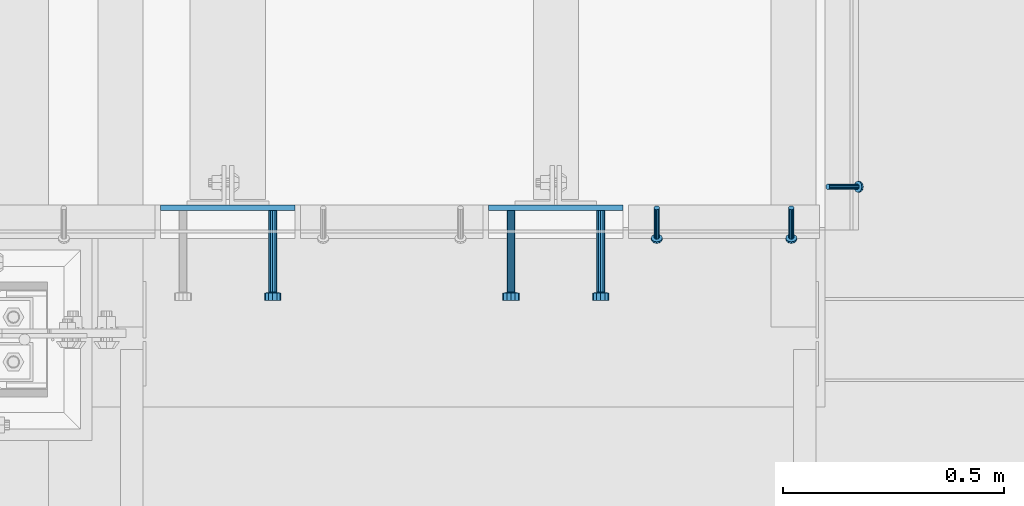
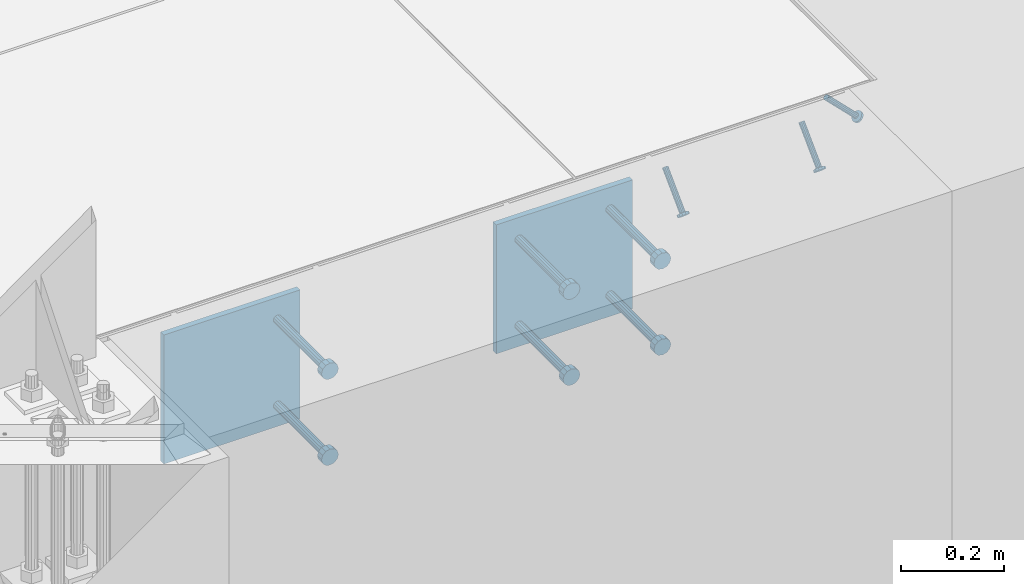
# One storey, part 2041 of 3843: 8 beams, 3 members, 4 elements without a shape of their own.
"""IFC2X3 building model written with IfcOpenShell, lengths in millimetres."""

from ifc_helpers import new_model, si_unit, frame, origin_with_axes, place, context, subcontext, project, spatial, faceted_brep, material, type_object, element, aggregate, save


model = new_model("IFC2X3")

# Units and contexts
model_context = context("Model", 3, precision=1e-05, world=origin_with_axes())
body_context = subcontext(model_context, "Body", "Model", "MODEL_VIEW")
ifc_project = project(units=[si_unit("LENGTHUNIT", "METRE", prefix="MILLI"), si_unit("AREAUNIT", "SQUARE_METRE"), si_unit("VOLUMEUNIT", "CUBIC_METRE"), si_unit("MASSUNIT", "GRAM", prefix="KILO"), si_unit("TIMEUNIT", "SECOND"), si_unit("PLANEANGLEUNIT", "RADIAN"), si_unit("SOLIDANGLEUNIT", "STERADIAN"), si_unit("THERMODYNAMICTEMPERATUREUNIT", "DEGREE_CELSIUS"), si_unit("LUMINOUSINTENSITYUNIT", "LUMEN")], contexts=[model_context])

# Site, building, storey
site_placement = place(None, origin_with_axes())
site = spatial("IfcSite", under=ifc_project, at=site_placement, CompositionType="ELEMENT")
building_placement = place(site_placement, origin_with_axes())
building = spatial("IfcBuilding", under=site, at=building_placement, Name="Undefined", CompositionType="ELEMENT")
storey_placement = place(building_placement, origin_with_axes())
storey = spatial("IfcBuildingStorey", under=building, at=storey_placement, Name="Undefined", CompositionType="ELEMENT", Elevation=0.0)

# Assembly, members
assembly_1_placement = place(storey_placement, origin_with_axes())
assembly_1 = element("IfcElementAssembly", 1, at=assembly_1_placement, inside=storey, Name="ANGLE", AssemblyPlace="NOTDEFINED", PredefinedType="RIGID_FRAME")
ifc_material_1 = material(Name="STEEL/A108")
member_type = type_object("IfcMemberType", PredefinedType="NOTDEFINED")
member_1_placement = place(assembly_1_placement, frame((50504.724998711, 15297.1500129542, 30397.4500030518), z_axis=(1.0, 0.0, 0.0), x_axis=(0.0, -0.707106781186548, -0.707106781186548)))
member_1 = element("IfcMember", 2, at=member_1_placement, type_object=member_type, material=ifc_material_1, Name="HEADED STUD ANCHOR", context=body_context, shape_type="Brep", body=[
    faceted_brep([(7.27595761418343e-12, -3.18000006675175, 5.5), (0.0, -5.49999999998363, 3.1800000667572), (94.4879985803855, -5.50000000011278, 3.1800000667572), (94.4879985803782, -3.18000006687362, 5.5), (0.0, -6.3499999046162, 0.0), (94.4879985803855, -6.34999990474535, 0.0), (0.0, -5.49999999998363, -3.1800000667572), (94.4879985803855, -5.50000000011278, -3.1800000667572), (7.27595761418343e-12, -3.18000006675175, -5.5), (94.4879985803782, -3.18000006687362, -5.5), (7.27595761418343e-12, -1.81898940354586e-12, -6.34999990463257), (94.4879985803782, -1.20053300634027e-10, -6.34999990463257), (0.0, 3.18000006675175, -5.5), (94.4879985803709, 3.18000006663351, -5.5), (7.27595761418343e-12, 5.49999999998363, -3.1800000667572), (94.4879985803709, 5.49999999987267, -3.1800000667572), (7.27595761418343e-12, 6.3499999046162, 0.0), (94.4879985803673, 6.34999990450706, 0.0), (7.27595761418343e-12, 5.49999999998363, 3.1800000667572), (94.4879985803709, 5.49999999987267, 3.1800000667572), (0.0, 3.18000006675175, 5.5), (94.4879985803709, 3.18000006663351, 5.5), (7.27595761418343e-12, -1.81898940354586e-12, 6.34999990463257), (94.4879985803782, -1.20053300634027e-10, 6.34999990463257), (96.5199985498621, -10.9899997712273, 6.34999990463257), (96.5199985498548, -6.34000015270249, 10.9899997711182), (96.5199985498621, -12.6999998093743, 0.0), (96.5199985498621, -10.9899997712273, -6.34999990463257), (96.5199985498548, -6.34000015270249, -10.9899997711182), (96.5199985498475, -1.21872290037572e-10, -12.6899995803833), (96.5199985498402, 6.34000015245874, -10.9899997711182), (96.519998549833, 10.9899997709817, -6.34999990463257), (96.519998549833, 12.6999998091305, 0.0), (96.519998549833, 10.9899997709817, 6.34999990463257), (96.5199985498402, 6.34000015245874, 10.9899997711182), (96.5199985498475, -1.21872290037572e-10, 12.6899995803833), (101.599998473539, -10.9899997712328, 6.34999990463257), (101.599998473532, -6.34000015270976, 10.9899997711182), (101.599998473539, -12.6999998093797, 0.0), (101.599998473539, -10.9899997712328, -6.34999990463257), (101.599998473532, -6.34000015270976, -10.9899997711182), (101.599998473524, -1.29148247651756e-10, -12.6899995803833), (101.599998473517, 6.34000015245329, -10.9899997711182), (101.59999847351, 10.9899997709763, -6.34999990463257), (101.599998473503, 12.6999998091196, 0.0), (101.59999847351, 10.9899997709763, 6.34999990463257), (101.599998473517, 6.34000015245329, 10.9899997711182), (101.599998473524, -1.29148247651756e-10, 12.6899995803833)], [[[0, 1, 2, 3]], [[1, 4, 5, 2]], [[4, 6, 7, 5]], [[6, 8, 9, 7]], [[8, 10, 11, 9]], [[10, 12, 13, 11]], [[12, 14, 15, 13]], [[14, 16, 17, 15]], [[16, 18, 19, 17]], [[18, 20, 21, 19]], [[20, 22, 23, 21]], [[22, 0, 3, 23]], [[22, 20, 18, 16, 14, 12, 10, 8, 6, 4, 1, 0]], [[3, 2, 24, 25]], [[2, 5, 26, 24]], [[5, 7, 27, 26]], [[7, 9, 28, 27]], [[9, 11, 29, 28]], [[11, 13, 30, 29]], [[13, 15, 31, 30]], [[15, 17, 32, 31]], [[17, 19, 33, 32]], [[19, 21, 34, 33]], [[21, 23, 35, 34]], [[23, 3, 25, 35]], [[25, 24, 36, 37]], [[24, 26, 38, 36]], [[26, 27, 39, 38]], [[27, 28, 40, 39]], [[28, 29, 41, 40]], [[29, 30, 42, 41]], [[30, 31, 43, 42]], [[31, 32, 44, 43]], [[32, 33, 45, 44]], [[33, 34, 46, 45]], [[34, 35, 47, 46]], [[35, 25, 37, 47]], [[38, 39, 40, 41, 42, 43, 44, 45, 46, 47, 37, 36]]]),
])
member_2_placement = place(assembly_1_placement, frame((50809.524998711, 15297.1500129542, 30397.4500030518), z_axis=(1.0, 0.0, 0.0), x_axis=(0.0, -0.707106781186548, -0.707106781186548)))
member_2 = element("IfcMember", 3, at=member_2_placement, type_object=member_type, material=ifc_material_1, Name="HEADED STUD ANCHOR", context=body_context, shape_type="Brep", body=[
    faceted_brep([(7.27595761418343e-12, -3.18000006675175, 5.5), (0.0, -5.49999999998363, 3.1800000667572), (94.4879985803855, -5.50000000011278, 3.1800000667572), (94.4879985803782, -3.18000006687362, 5.5), (0.0, -6.3499999046162, 0.0), (94.4879985803855, -6.34999990474535, 0.0), (0.0, -5.49999999998363, -3.1800000667572), (94.4879985803855, -5.50000000011278, -3.1800000667572), (7.27595761418343e-12, -3.18000006675175, -5.5), (94.4879985803782, -3.18000006687362, -5.5), (7.27595761418343e-12, -1.81898940354586e-12, -6.34999990463257), (94.4879985803782, -1.20053300634027e-10, -6.34999990463257), (0.0, 3.18000006675175, -5.5), (94.4879985803709, 3.18000006663351, -5.5), (7.27595761418343e-12, 5.49999999998363, -3.1800000667572), (94.4879985803709, 5.49999999987267, -3.1800000667572), (7.27595761418343e-12, 6.3499999046162, 0.0), (94.4879985803673, 6.34999990450706, 0.0), (7.27595761418343e-12, 5.49999999998363, 3.1800000667572), (94.4879985803709, 5.49999999987267, 3.1800000667572), (0.0, 3.18000006675175, 5.5), (94.4879985803709, 3.18000006663351, 5.5), (7.27595761418343e-12, -1.81898940354586e-12, 6.34999990463257), (94.4879985803782, -1.20053300634027e-10, 6.34999990463257), (96.5199985498621, -10.9899997712273, 6.34999990463257), (96.5199985498548, -6.34000015270249, 10.9899997711182), (96.5199985498621, -12.6999998093743, 0.0), (96.5199985498621, -10.9899997712273, -6.34999990463257), (96.5199985498548, -6.34000015270249, -10.9899997711182), (96.5199985498475, -1.21872290037572e-10, -12.6899995803833), (96.5199985498402, 6.34000015245874, -10.9899997711182), (96.519998549833, 10.9899997709817, -6.34999990463257), (96.519998549833, 12.6999998091305, 0.0), (96.519998549833, 10.9899997709817, 6.34999990463257), (96.5199985498402, 6.34000015245874, 10.9899997711182), (96.5199985498475, -1.21872290037572e-10, 12.6899995803833), (101.599998473539, -10.9899997712328, 6.34999990463257), (101.599998473532, -6.34000015270976, 10.9899997711182), (101.599998473539, -12.6999998093797, 0.0), (101.599998473539, -10.9899997712328, -6.34999990463257), (101.599998473532, -6.34000015270976, -10.9899997711182), (101.599998473524, -1.29148247651756e-10, -12.6899995803833), (101.599998473517, 6.34000015245329, -10.9899997711182), (101.59999847351, 10.9899997709763, -6.34999990463257), (101.599998473503, 12.6999998091196, 0.0), (101.59999847351, 10.9899997709763, 6.34999990463257), (101.599998473517, 6.34000015245329, 10.9899997711182), (101.599998473524, -1.29148247651756e-10, 12.6899995803833)], [[[0, 1, 2, 3]], [[1, 4, 5, 2]], [[4, 6, 7, 5]], [[6, 8, 9, 7]], [[8, 10, 11, 9]], [[10, 12, 13, 11]], [[12, 14, 15, 13]], [[14, 16, 17, 15]], [[16, 18, 19, 17]], [[18, 20, 21, 19]], [[20, 22, 23, 21]], [[22, 0, 3, 23]], [[22, 20, 18, 16, 14, 12, 10, 8, 6, 4, 1, 0]], [[3, 2, 24, 25]], [[2, 5, 26, 24]], [[5, 7, 27, 26]], [[7, 9, 28, 27]], [[9, 11, 29, 28]], [[11, 13, 30, 29]], [[13, 15, 31, 30]], [[15, 17, 32, 31]], [[17, 19, 33, 32]], [[19, 21, 34, 33]], [[21, 23, 35, 34]], [[23, 3, 25, 35]], [[25, 24, 36, 37]], [[24, 26, 38, 36]], [[26, 27, 39, 38]], [[27, 28, 40, 39]], [[28, 29, 41, 40]], [[29, 30, 42, 41]], [[30, 31, 43, 42]], [[31, 32, 44, 43]], [[32, 33, 45, 44]], [[33, 34, 46, 45]], [[34, 35, 47, 46]], [[35, 25, 37, 47]], [[38, 39, 40, 41, 42, 43, 44, 45, 46, 47, 37, 36]]]),
])
aggregate(assembly_1, [member_1, member_2])

# Assembly, member
assembly_2_placement = place(storey_placement, origin_with_axes())
assembly_2 = element("IfcElementAssembly", 4, at=assembly_2_placement, inside=storey, Name="ANGLE", AssemblyPlace="NOTDEFINED", PredefinedType="RIGID_FRAME")
member_3_placement = place(assembly_2_placement, frame((50892.0749998585, 15344.7751129179, 30397.4500030517), z_axis=(0.0, 1.0, 0.0), x_axis=(0.707106781186548, 0.0, -0.707106781186548)))
member_3 = element("IfcMember", 5, at=member_3_placement, type_object=member_type, material=ifc_material_1, Name="HEADED STUD ANCHOR", context=body_context, shape_type="Brep", body=[
    faceted_brep([(7.27595761418343e-12, -3.18000006675175, 5.5), (0.0, -5.49999999998363, 3.1800000667572), (94.4879985803855, -5.50000000011278, 3.1800000667572), (94.4879985803782, -3.18000006687362, 5.5), (0.0, -6.3499999046162, 0.0), (94.4879985803855, -6.34999990474535, 0.0), (0.0, -5.49999999998363, -3.1800000667572), (94.4879985803855, -5.50000000011278, -3.1800000667572), (7.27595761418343e-12, -3.18000006675175, -5.5), (94.4879985803782, -3.18000006687362, -5.5), (7.27595761418343e-12, -1.81898940354586e-12, -6.34999990463257), (94.4879985803782, -1.20053300634027e-10, -6.34999990463257), (0.0, 3.18000006675175, -5.5), (94.4879985803709, 3.18000006663351, -5.5), (7.27595761418343e-12, 5.49999999998363, -3.1800000667572), (94.4879985803709, 5.49999999987267, -3.1800000667572), (7.27595761418343e-12, 6.3499999046162, 0.0), (94.4879985803673, 6.34999990450706, 0.0), (7.27595761418343e-12, 5.49999999998363, 3.1800000667572), (94.4879985803709, 5.49999999987267, 3.1800000667572), (0.0, 3.18000006675175, 5.5), (94.4879985803709, 3.18000006663351, 5.5), (7.27595761418343e-12, -1.81898940354586e-12, 6.34999990463257), (94.4879985803782, -1.20053300634027e-10, 6.34999990463257), (96.5199985498621, -10.9899997712273, 6.34999990463257), (96.5199985498548, -6.34000015270249, 10.9899997711182), (96.5199985498621, -12.6999998093743, 0.0), (96.5199985498621, -10.9899997712273, -6.34999990463257), (96.5199985498548, -6.34000015270249, -10.9899997711182), (96.5199985498475, -1.21872290037572e-10, -12.6899995803833), (96.5199985498402, 6.34000015245874, -10.9899997711182), (96.519998549833, 10.9899997709817, -6.34999990463257), (96.519998549833, 12.6999998091305, 0.0), (96.519998549833, 10.9899997709817, 6.34999990463257), (96.5199985498402, 6.34000015245874, 10.9899997711182), (96.5199985498475, -1.21872290037572e-10, 12.6899995803833), (101.599998473539, -10.9899997712328, 6.34999990463257), (101.599998473532, -6.34000015270976, 10.9899997711182), (101.599998473539, -12.6999998093797, 0.0), (101.599998473539, -10.9899997712328, -6.34999990463257), (101.599998473532, -6.34000015270976, -10.9899997711182), (101.599998473524, -1.29148247651756e-10, -12.6899995803833), (101.599998473517, 6.34000015245329, -10.9899997711182), (101.59999847351, 10.9899997709763, -6.34999990463257), (101.599998473503, 12.6999998091196, 0.0), (101.59999847351, 10.9899997709763, 6.34999990463257), (101.599998473517, 6.34000015245329, 10.9899997711182), (101.599998473524, -1.29148247651756e-10, 12.6899995803833)], [[[0, 1, 2, 3]], [[1, 4, 5, 2]], [[4, 6, 7, 5]], [[6, 8, 9, 7]], [[8, 10, 11, 9]], [[10, 12, 13, 11]], [[12, 14, 15, 13]], [[14, 16, 17, 15]], [[16, 18, 19, 17]], [[18, 20, 21, 19]], [[20, 22, 23, 21]], [[22, 0, 3, 23]], [[22, 20, 18, 16, 14, 12, 10, 8, 6, 4, 1, 0]], [[3, 2, 24, 25]], [[2, 5, 26, 24]], [[5, 7, 27, 26]], [[7, 9, 28, 27]], [[9, 11, 29, 28]], [[11, 13, 30, 29]], [[13, 15, 31, 30]], [[15, 17, 32, 31]], [[17, 19, 33, 32]], [[19, 21, 34, 33]], [[21, 23, 35, 34]], [[23, 3, 25, 35]], [[25, 24, 36, 37]], [[24, 26, 38, 36]], [[26, 27, 39, 38]], [[27, 28, 40, 39]], [[28, 29, 41, 40]], [[29, 30, 42, 41]], [[30, 31, 43, 42]], [[31, 32, 44, 43]], [[32, 33, 45, 44]], [[33, 34, 46, 45]], [[34, 35, 47, 46]], [[35, 25, 37, 47]], [[38, 39, 40, 41, 42, 43, 44, 45, 46, 47, 37, 36]]]),
])
aggregate(assembly_2, [member_3])

# Assembly, beam
assembly_3_placement = place(storey_placement, origin_with_axes())
assembly_3 = element("IfcElementAssembly", 6, at=assembly_3_placement, inside=storey, Name="EMBED PLATE", AssemblyPlace="NOTDEFINED", PredefinedType="RIGID_FRAME")
ifc_material_2 = material(Name="STEEL/A36")
beam_type_1 = type_object("IfcBeamType", PredefinedType="NOTDEFINED")
beam_1_placement = place(assembly_3_placement, frame((50276.125, 15297.1500030518, 30397.45), z_axis=(-1.0, 0.0, 0.0), x_axis=(0.0, 0.0, -1.0)))
beam_1 = element("IfcBeam", 7, at=beam_1_placement, type_object=beam_type_1, material=ifc_material_2, Name="EMBED PLATE", context=body_context, shape_type="Brep", body=[
    faceted_brep([(-1.0550138540566e-10, 6.34999999999854, -152.400000000664), (1.0550138540566e-10, 6.34999999999854, 152.400000000656), (304.799999999999, 6.34999999999854, 152.400000000001), (304.799999999999, 6.34999999999854, -152.400000000001), (1.0550138540566e-10, -6.34999999999854, 152.400000000656), (304.799999999999, -6.34999999999854, 152.400000000001), (-1.0550138540566e-10, -6.34999999999854, -152.400000000664), (304.799999999999, -6.34999999999854, -152.400000000001)], [[[0, 1, 2, 3]], [[1, 4, 5, 2]], [[4, 6, 7, 5]], [[6, 0, 3, 7]], [[5, 7, 3, 2]], [[6, 4, 1, 0]]]),
])

assembly_4_placement = place(storey_placement, origin_with_axes())
assembly_4 = element("IfcElementAssembly", 8, at=assembly_4_placement, inside=storey, Name="EMBED PLATE", AssemblyPlace="NOTDEFINED", PredefinedType="RIGID_FRAME")
beam_2_placement = place(assembly_4_placement, frame((49533.175, 15297.1500030518, 30397.45), z_axis=(-1.0, 0.0, 0.0), x_axis=(0.0, 0.0, -1.0)))
beam_2 = element("IfcBeam", 9, at=beam_2_placement, type_object=beam_type_1, material=ifc_material_2, Name="EMBED PLATE", context=body_context, shape_type="Brep", body=[
    faceted_brep([(-1.0550138540566e-10, 6.34999999999854, -152.400000000664), (1.0550138540566e-10, 6.34999999999854, 152.400000000656), (304.799999999999, 6.34999999999854, 152.400000000001), (304.799999999999, 6.34999999999854, -152.400000000001), (1.0550138540566e-10, -6.34999999999854, 152.400000000656), (304.799999999999, -6.34999999999854, 152.400000000001), (-1.0550138540566e-10, -6.34999999999854, -152.400000000664), (304.799999999999, -6.34999999999854, -152.400000000001)], [[[0, 1, 2, 3]], [[1, 4, 5, 2]], [[4, 6, 7, 5]], [[6, 0, 3, 7]], [[5, 7, 3, 2]], [[6, 4, 1, 0]]]),
])

# Beam
beam_type_2 = type_object("IfcBeamType", PredefinedType="NOTDEFINED")
beam_3_placement = place(assembly_3_placement, frame((50377.725, 15290.8000030518, 30346.65), z_axis=(1.0, 0.0, 0.0), x_axis=(0.0, -1.0, 0.0)))
beam_3 = element("IfcBeam", 10, at=beam_3_placement, type_object=beam_type_2, material=ifc_material_1, Name="HEADED STUD ANCHOR", context=body_context, shape_type="Brep", body=[
    faceted_brep([(0.0, -9.52000045776367, 0.0), (0.0, -8.25, -4.76000022888184), (184.912000000004, -8.25, -4.76000022888184), (184.912000000004, -9.52000045776367, 0.0), (0.0, -4.76000022888184, -8.25), (184.912000000004, -4.76000022888184, -8.25), (0.0, 0.0, -9.52000045776367), (184.912000000004, 0.0, -9.52000045776367), (0.0, 4.76000022888184, -8.25), (184.912000000004, 4.76000022888184, -8.25), (0.0, 8.25, -4.76000022888184), (184.912000000004, 8.25, -4.76000022888184), (0.0, 9.52000045776367, 0.0), (184.912000000004, 9.52000045776367, 0.0), (0.0, 8.25, 4.76000022888184), (184.912000000004, 8.25, 4.76000022888184), (0.0, 4.76000022888184, 8.25), (184.912000000004, 4.76000022888184, 8.25), (0.0, 0.0, 9.52000045776367), (184.912000000004, 0.0, 9.52000045776367), (0.0, -4.76000022888184, 8.25), (184.912000000004, -4.76000022888184, 8.25), (0.0, -8.25, 4.76000022888184), (184.912000000004, -8.25, 4.76000022888184), (186.944000000003, -16.5, -9.52000045776367), (186.944000000003, -19.0499992370605, 0.0), (186.944000000003, -9.52000045776367, -16.5), (186.944000000003, 0.0, -19.0499992370605), (186.944000000003, 9.52000045776367, -16.5), (186.944000000003, 16.5, -9.52000045776367), (186.944000000003, 19.0499992370605, 0.0), (186.944000000003, 16.5, 9.52000045776367), (186.944000000003, 9.52000045776367, 16.5), (186.944000000003, 0.0, 19.0499992370605), (186.944000000003, -9.52000045776367, 16.5), (186.944000000003, -16.5, 9.52000045776367), (203.199999999997, -16.5, -9.52000045776367), (203.199999999997, -19.0499992370605, 0.0), (203.199999999997, -9.52000045776367, -16.5), (203.199999999997, 0.0, -19.0499992370605), (203.199999999997, 9.52000045776367, -16.5), (203.199999999997, 16.5, -9.52000045776367), (203.199999999997, 19.0499992370605, 0.0), (203.199999999997, 16.5, 9.52000045776367), (203.199999999997, 9.52000045776367, 16.5), (203.199999999997, 0.0, 19.0499992370605), (203.199999999997, -9.52000045776367, 16.5), (203.199999999997, -16.5, 9.52000045776367)], [[[0, 1, 2, 3]], [[1, 4, 5, 2]], [[4, 6, 7, 5]], [[6, 8, 9, 7]], [[8, 10, 11, 9]], [[10, 12, 13, 11]], [[12, 14, 15, 13]], [[14, 16, 17, 15]], [[16, 18, 19, 17]], [[18, 20, 21, 19]], [[20, 22, 23, 21]], [[22, 0, 3, 23]], [[22, 20, 18, 16, 14, 12, 10, 8, 6, 4, 1, 0]], [[3, 2, 24, 25]], [[2, 5, 26, 24]], [[5, 7, 27, 26]], [[7, 9, 28, 27]], [[9, 11, 29, 28]], [[11, 13, 30, 29]], [[13, 15, 31, 30]], [[15, 17, 32, 31]], [[17, 19, 33, 32]], [[19, 21, 34, 33]], [[21, 23, 35, 34]], [[23, 3, 25, 35]], [[25, 24, 36, 37]], [[24, 26, 38, 36]], [[26, 27, 39, 38]], [[27, 28, 40, 39]], [[28, 29, 41, 40]], [[29, 30, 42, 41]], [[30, 31, 43, 42]], [[31, 32, 44, 43]], [[32, 33, 45, 44]], [[33, 34, 46, 45]], [[34, 35, 47, 46]], [[35, 25, 37, 47]], [[38, 39, 40, 41, 42, 43, 44, 45, 46, 47, 37, 36]]]),
])

beam_4_placement = place(assembly_3_placement, frame((50377.725, 15290.8000030518, 30143.45), z_axis=(1.0, 0.0, 0.0), x_axis=(0.0, -1.0, 0.0)))
beam_4 = element("IfcBeam", 11, at=beam_4_placement, type_object=beam_type_2, material=ifc_material_1, Name="HEADED STUD ANCHOR", context=body_context, shape_type="Brep", body=[
    faceted_brep([(0.0, -9.52000045776367, 0.0), (0.0, -8.25, -4.76000022888184), (184.912000000004, -8.25, -4.76000022888184), (184.912000000004, -9.52000045776367, 0.0), (0.0, -4.76000022888184, -8.25), (184.912000000004, -4.76000022888184, -8.25), (0.0, 0.0, -9.52000045776367), (184.912000000004, 0.0, -9.52000045776367), (0.0, 4.76000022888184, -8.25), (184.912000000004, 4.76000022888184, -8.25), (0.0, 8.25, -4.76000022888184), (184.912000000004, 8.25, -4.76000022888184), (0.0, 9.52000045776367, 0.0), (184.912000000004, 9.52000045776367, 0.0), (0.0, 8.25, 4.76000022888184), (184.912000000004, 8.25, 4.76000022888184), (0.0, 4.76000022888184, 8.25), (184.912000000004, 4.76000022888184, 8.25), (0.0, 0.0, 9.52000045776367), (184.912000000004, 0.0, 9.52000045776367), (0.0, -4.76000022888184, 8.25), (184.912000000004, -4.76000022888184, 8.25), (0.0, -8.25, 4.76000022888184), (184.912000000004, -8.25, 4.76000022888184), (186.944000000003, -16.5, -9.52000045776367), (186.944000000003, -19.0499992370605, 0.0), (186.944000000003, -9.52000045776367, -16.5), (186.944000000003, 0.0, -19.0499992370605), (186.944000000003, 9.52000045776367, -16.5), (186.944000000003, 16.5, -9.52000045776367), (186.944000000003, 19.0499992370605, 0.0), (186.944000000003, 16.5, 9.52000045776367), (186.944000000003, 9.52000045776367, 16.5), (186.944000000003, 0.0, 19.0499992370605), (186.944000000003, -9.52000045776367, 16.5), (186.944000000003, -16.5, 9.52000045776367), (203.199999999997, -16.5, -9.52000045776367), (203.199999999997, -19.0499992370605, 0.0), (203.199999999997, -9.52000045776367, -16.5), (203.199999999997, 0.0, -19.0499992370605), (203.199999999997, 9.52000045776367, -16.5), (203.199999999997, 16.5, -9.52000045776367), (203.199999999997, 19.0499992370605, 0.0), (203.199999999997, 16.5, 9.52000045776367), (203.199999999997, 9.52000045776367, 16.5), (203.199999999997, 0.0, 19.0499992370605), (203.199999999997, -9.52000045776367, 16.5), (203.199999999997, -16.5, 9.52000045776367)], [[[0, 1, 2, 3]], [[1, 4, 5, 2]], [[4, 6, 7, 5]], [[6, 8, 9, 7]], [[8, 10, 11, 9]], [[10, 12, 13, 11]], [[12, 14, 15, 13]], [[14, 16, 17, 15]], [[16, 18, 19, 17]], [[18, 20, 21, 19]], [[20, 22, 23, 21]], [[22, 0, 3, 23]], [[22, 20, 18, 16, 14, 12, 10, 8, 6, 4, 1, 0]], [[3, 2, 24, 25]], [[2, 5, 26, 24]], [[5, 7, 27, 26]], [[7, 9, 28, 27]], [[9, 11, 29, 28]], [[11, 13, 30, 29]], [[13, 15, 31, 30]], [[15, 17, 32, 31]], [[17, 19, 33, 32]], [[19, 21, 34, 33]], [[21, 23, 35, 34]], [[23, 3, 25, 35]], [[25, 24, 36, 37]], [[24, 26, 38, 36]], [[26, 27, 39, 38]], [[27, 28, 40, 39]], [[28, 29, 41, 40]], [[29, 30, 42, 41]], [[30, 31, 43, 42]], [[31, 32, 44, 43]], [[32, 33, 45, 44]], [[33, 34, 46, 45]], [[34, 35, 47, 46]], [[35, 25, 37, 47]], [[38, 39, 40, 41, 42, 43, 44, 45, 46, 47, 37, 36]]]),
])

beam_5_placement = place(assembly_3_placement, frame((50174.525, 15290.8000030518, 30346.65), z_axis=(1.0, 0.0, 0.0), x_axis=(0.0, -1.0, 0.0)))
beam_5 = element("IfcBeam", 12, at=beam_5_placement, type_object=beam_type_2, material=ifc_material_2, Name="PLATE", context=body_context, shape_type="Brep", body=[
    faceted_brep([(0.0, -9.52000045776367, 0.0), (0.0, -8.25, -4.76000022888184), (184.912000000004, -8.25, -4.76000022888184), (184.912000000004, -9.52000045776367, 0.0), (0.0, -4.76000022888184, -8.25), (184.912000000004, -4.76000022888184, -8.25), (0.0, 0.0, -9.52000045776367), (184.912000000004, 0.0, -9.52000045776367), (0.0, 4.76000022888184, -8.25), (184.912000000004, 4.76000022888184, -8.25), (0.0, 8.25, -4.76000022888184), (184.912000000004, 8.25, -4.76000022888184), (0.0, 9.52000045776367, 0.0), (184.912000000004, 9.52000045776367, 0.0), (0.0, 8.25, 4.76000022888184), (184.912000000004, 8.25, 4.76000022888184), (0.0, 4.76000022888184, 8.25), (184.912000000004, 4.76000022888184, 8.25), (0.0, 0.0, 9.52000045776367), (184.912000000004, 0.0, 9.52000045776367), (0.0, -4.76000022888184, 8.25), (184.912000000004, -4.76000022888184, 8.25), (0.0, -8.25, 4.76000022888184), (184.912000000004, -8.25, 4.76000022888184), (186.944000000003, -16.5, -9.52000045776367), (186.944000000003, -19.0499992370605, 0.0), (186.944000000003, -9.52000045776367, -16.5), (186.944000000003, 0.0, -19.0499992370605), (186.944000000003, 9.52000045776367, -16.5), (186.944000000003, 16.5, -9.52000045776367), (186.944000000003, 19.0499992370605, 0.0), (186.944000000003, 16.5, 9.52000045776367), (186.944000000003, 9.52000045776367, 16.5), (186.944000000003, 0.0, 19.0499992370605), (186.944000000003, -9.52000045776367, 16.5), (186.944000000003, -16.5, 9.52000045776367), (203.199999999997, -16.5, -9.52000045776367), (203.199999999997, -19.0499992370605, 0.0), (203.199999999997, -9.52000045776367, -16.5), (203.199999999997, 0.0, -19.0499992370605), (203.199999999997, 9.52000045776367, -16.5), (203.199999999997, 16.5, -9.52000045776367), (203.199999999997, 19.0499992370605, 0.0), (203.199999999997, 16.5, 9.52000045776367), (203.199999999997, 9.52000045776367, 16.5), (203.199999999997, 0.0, 19.0499992370605), (203.199999999997, -9.52000045776367, 16.5), (203.199999999997, -16.5, 9.52000045776367)], [[[0, 1, 2, 3]], [[1, 4, 5, 2]], [[4, 6, 7, 5]], [[6, 8, 9, 7]], [[8, 10, 11, 9]], [[10, 12, 13, 11]], [[12, 14, 15, 13]], [[14, 16, 17, 15]], [[16, 18, 19, 17]], [[18, 20, 21, 19]], [[20, 22, 23, 21]], [[22, 0, 3, 23]], [[22, 20, 18, 16, 14, 12, 10, 8, 6, 4, 1, 0]], [[3, 2, 24, 25]], [[2, 5, 26, 24]], [[5, 7, 27, 26]], [[7, 9, 28, 27]], [[9, 11, 29, 28]], [[11, 13, 30, 29]], [[13, 15, 31, 30]], [[15, 17, 32, 31]], [[17, 19, 33, 32]], [[19, 21, 34, 33]], [[21, 23, 35, 34]], [[23, 3, 25, 35]], [[25, 24, 36, 37]], [[24, 26, 38, 36]], [[26, 27, 39, 38]], [[27, 28, 40, 39]], [[28, 29, 41, 40]], [[29, 30, 42, 41]], [[30, 31, 43, 42]], [[31, 32, 44, 43]], [[32, 33, 45, 44]], [[33, 34, 46, 45]], [[34, 35, 47, 46]], [[35, 25, 37, 47]], [[38, 39, 40, 41, 42, 43, 44, 45, 46, 47, 37, 36]]]),
])

beam_6_placement = place(assembly_3_placement, frame((50174.525, 15290.8000030518, 30143.45), z_axis=(1.0, 0.0, 0.0), x_axis=(0.0, -1.0, 0.0)))
beam_6 = element("IfcBeam", 13, at=beam_6_placement, type_object=beam_type_2, material=ifc_material_1, Name="HEADED STUD ANCHOR", context=body_context, shape_type="Brep", body=[
    faceted_brep([(0.0, -9.52000045776367, 0.0), (0.0, -8.25, -4.76000022888184), (184.912000000004, -8.25, -4.76000022888184), (184.912000000004, -9.52000045776367, 0.0), (0.0, -4.76000022888184, -8.25), (184.912000000004, -4.76000022888184, -8.25), (0.0, 0.0, -9.52000045776367), (184.912000000004, 0.0, -9.52000045776367), (0.0, 4.76000022888184, -8.25), (184.912000000004, 4.76000022888184, -8.25), (0.0, 8.25, -4.76000022888184), (184.912000000004, 8.25, -4.76000022888184), (0.0, 9.52000045776367, 0.0), (184.912000000004, 9.52000045776367, 0.0), (0.0, 8.25, 4.76000022888184), (184.912000000004, 8.25, 4.76000022888184), (0.0, 4.76000022888184, 8.25), (184.912000000004, 4.76000022888184, 8.25), (0.0, 0.0, 9.52000045776367), (184.912000000004, 0.0, 9.52000045776367), (0.0, -4.76000022888184, 8.25), (184.912000000004, -4.76000022888184, 8.25), (0.0, -8.25, 4.76000022888184), (184.912000000004, -8.25, 4.76000022888184), (186.944000000003, -16.5, -9.52000045776367), (186.944000000003, -19.0499992370605, 0.0), (186.944000000003, -9.52000045776367, -16.5), (186.944000000003, 0.0, -19.0499992370605), (186.944000000003, 9.52000045776367, -16.5), (186.944000000003, 16.5, -9.52000045776367), (186.944000000003, 19.0499992370605, 0.0), (186.944000000003, 16.5, 9.52000045776367), (186.944000000003, 9.52000045776367, 16.5), (186.944000000003, 0.0, 19.0499992370605), (186.944000000003, -9.52000045776367, 16.5), (186.944000000003, -16.5, 9.52000045776367), (203.199999999997, -16.5, -9.52000045776367), (203.199999999997, -19.0499992370605, 0.0), (203.199999999997, -9.52000045776367, -16.5), (203.199999999997, 0.0, -19.0499992370605), (203.199999999997, 9.52000045776367, -16.5), (203.199999999997, 16.5, -9.52000045776367), (203.199999999997, 19.0499992370605, 0.0), (203.199999999997, 16.5, 9.52000045776367), (203.199999999997, 9.52000045776367, 16.5), (203.199999999997, 0.0, 19.0499992370605), (203.199999999997, -9.52000045776367, 16.5), (203.199999999997, -16.5, 9.52000045776367)], [[[0, 1, 2, 3]], [[1, 4, 5, 2]], [[4, 6, 7, 5]], [[6, 8, 9, 7]], [[8, 10, 11, 9]], [[10, 12, 13, 11]], [[12, 14, 15, 13]], [[14, 16, 17, 15]], [[16, 18, 19, 17]], [[18, 20, 21, 19]], [[20, 22, 23, 21]], [[22, 0, 3, 23]], [[22, 20, 18, 16, 14, 12, 10, 8, 6, 4, 1, 0]], [[3, 2, 24, 25]], [[2, 5, 26, 24]], [[5, 7, 27, 26]], [[7, 9, 28, 27]], [[9, 11, 29, 28]], [[11, 13, 30, 29]], [[13, 15, 31, 30]], [[15, 17, 32, 31]], [[17, 19, 33, 32]], [[19, 21, 34, 33]], [[21, 23, 35, 34]], [[23, 3, 25, 35]], [[25, 24, 36, 37]], [[24, 26, 38, 36]], [[26, 27, 39, 38]], [[27, 28, 40, 39]], [[28, 29, 41, 40]], [[29, 30, 42, 41]], [[30, 31, 43, 42]], [[31, 32, 44, 43]], [[32, 33, 45, 44]], [[33, 34, 46, 45]], [[34, 35, 47, 46]], [[35, 25, 37, 47]], [[38, 39, 40, 41, 42, 43, 44, 45, 46, 47, 37, 36]]]),
])

aggregate(assembly_3, [beam_3, beam_4, beam_5, beam_6, beam_1])

beam_7_placement = place(assembly_4_placement, frame((49634.775, 15290.8000030518, 30346.65), z_axis=(1.0, 0.0, 0.0), x_axis=(0.0, -1.0, 0.0)))
beam_7 = element("IfcBeam", 14, at=beam_7_placement, type_object=beam_type_2, material=ifc_material_1, Name="HEADED STUD ANCHOR", context=body_context, shape_type="Brep", body=[
    faceted_brep([(0.0, -9.52000045776367, 0.0), (0.0, -8.25, -4.76000022888184), (184.912000000004, -8.25, -4.76000022888184), (184.912000000004, -9.52000045776367, 0.0), (0.0, -4.76000022888184, -8.25), (184.912000000004, -4.76000022888184, -8.25), (0.0, 0.0, -9.52000045776367), (184.912000000004, 0.0, -9.52000045776367), (0.0, 4.76000022888184, -8.25), (184.912000000004, 4.76000022888184, -8.25), (0.0, 8.25, -4.76000022888184), (184.912000000004, 8.25, -4.76000022888184), (0.0, 9.52000045776367, 0.0), (184.912000000004, 9.52000045776367, 0.0), (0.0, 8.25, 4.76000022888184), (184.912000000004, 8.25, 4.76000022888184), (0.0, 4.76000022888184, 8.25), (184.912000000004, 4.76000022888184, 8.25), (0.0, 0.0, 9.52000045776367), (184.912000000004, 0.0, 9.52000045776367), (0.0, -4.76000022888184, 8.25), (184.912000000004, -4.76000022888184, 8.25), (0.0, -8.25, 4.76000022888184), (184.912000000004, -8.25, 4.76000022888184), (186.944000000003, -16.5, -9.52000045776367), (186.944000000003, -19.0499992370605, 0.0), (186.944000000003, -9.52000045776367, -16.5), (186.944000000003, 0.0, -19.0499992370605), (186.944000000003, 9.52000045776367, -16.5), (186.944000000003, 16.5, -9.52000045776367), (186.944000000003, 19.0499992370605, 0.0), (186.944000000003, 16.5, 9.52000045776367), (186.944000000003, 9.52000045776367, 16.5), (186.944000000003, 0.0, 19.0499992370605), (186.944000000003, -9.52000045776367, 16.5), (186.944000000003, -16.5, 9.52000045776367), (203.199999999997, -16.5, -9.52000045776367), (203.199999999997, -19.0499992370605, 0.0), (203.199999999997, -9.52000045776367, -16.5), (203.199999999997, 0.0, -19.0499992370605), (203.199999999997, 9.52000045776367, -16.5), (203.199999999997, 16.5, -9.52000045776367), (203.199999999997, 19.0499992370605, 0.0), (203.199999999997, 16.5, 9.52000045776367), (203.199999999997, 9.52000045776367, 16.5), (203.199999999997, 0.0, 19.0499992370605), (203.199999999997, -9.52000045776367, 16.5), (203.199999999997, -16.5, 9.52000045776367)], [[[0, 1, 2, 3]], [[1, 4, 5, 2]], [[4, 6, 7, 5]], [[6, 8, 9, 7]], [[8, 10, 11, 9]], [[10, 12, 13, 11]], [[12, 14, 15, 13]], [[14, 16, 17, 15]], [[16, 18, 19, 17]], [[18, 20, 21, 19]], [[20, 22, 23, 21]], [[22, 0, 3, 23]], [[22, 20, 18, 16, 14, 12, 10, 8, 6, 4, 1, 0]], [[3, 2, 24, 25]], [[2, 5, 26, 24]], [[5, 7, 27, 26]], [[7, 9, 28, 27]], [[9, 11, 29, 28]], [[11, 13, 30, 29]], [[13, 15, 31, 30]], [[15, 17, 32, 31]], [[17, 19, 33, 32]], [[19, 21, 34, 33]], [[21, 23, 35, 34]], [[23, 3, 25, 35]], [[25, 24, 36, 37]], [[24, 26, 38, 36]], [[26, 27, 39, 38]], [[27, 28, 40, 39]], [[28, 29, 41, 40]], [[29, 30, 42, 41]], [[30, 31, 43, 42]], [[31, 32, 44, 43]], [[32, 33, 45, 44]], [[33, 34, 46, 45]], [[34, 35, 47, 46]], [[35, 25, 37, 47]], [[38, 39, 40, 41, 42, 43, 44, 45, 46, 47, 37, 36]]]),
])

beam_8_placement = place(assembly_4_placement, frame((49634.775, 15290.8000030518, 30143.45), z_axis=(1.0, 0.0, 0.0), x_axis=(0.0, -1.0, 0.0)))
beam_8 = element("IfcBeam", 15, at=beam_8_placement, type_object=beam_type_2, material=ifc_material_1, Name="HEADED STUD ANCHOR", context=body_context, shape_type="Brep", body=[
    faceted_brep([(0.0, -9.52000045776367, 0.0), (0.0, -8.25, -4.76000022888184), (184.912000000004, -8.25, -4.76000022888184), (184.912000000004, -9.52000045776367, 0.0), (0.0, -4.76000022888184, -8.25), (184.912000000004, -4.76000022888184, -8.25), (0.0, 0.0, -9.52000045776367), (184.912000000004, 0.0, -9.52000045776367), (0.0, 4.76000022888184, -8.25), (184.912000000004, 4.76000022888184, -8.25), (0.0, 8.25, -4.76000022888184), (184.912000000004, 8.25, -4.76000022888184), (0.0, 9.52000045776367, 0.0), (184.912000000004, 9.52000045776367, 0.0), (0.0, 8.25, 4.76000022888184), (184.912000000004, 8.25, 4.76000022888184), (0.0, 4.76000022888184, 8.25), (184.912000000004, 4.76000022888184, 8.25), (0.0, 0.0, 9.52000045776367), (184.912000000004, 0.0, 9.52000045776367), (0.0, -4.76000022888184, 8.25), (184.912000000004, -4.76000022888184, 8.25), (0.0, -8.25, 4.76000022888184), (184.912000000004, -8.25, 4.76000022888184), (186.944000000003, -16.5, -9.52000045776367), (186.944000000003, -19.0499992370605, 0.0), (186.944000000003, -9.52000045776367, -16.5), (186.944000000003, 0.0, -19.0499992370605), (186.944000000003, 9.52000045776367, -16.5), (186.944000000003, 16.5, -9.52000045776367), (186.944000000003, 19.0499992370605, 0.0), (186.944000000003, 16.5, 9.52000045776367), (186.944000000003, 9.52000045776367, 16.5), (186.944000000003, 0.0, 19.0499992370605), (186.944000000003, -9.52000045776367, 16.5), (186.944000000003, -16.5, 9.52000045776367), (203.199999999997, -16.5, -9.52000045776367), (203.199999999997, -19.0499992370605, 0.0), (203.199999999997, -9.52000045776367, -16.5), (203.199999999997, 0.0, -19.0499992370605), (203.199999999997, 9.52000045776367, -16.5), (203.199999999997, 16.5, -9.52000045776367), (203.199999999997, 19.0499992370605, 0.0), (203.199999999997, 16.5, 9.52000045776367), (203.199999999997, 9.52000045776367, 16.5), (203.199999999997, 0.0, 19.0499992370605), (203.199999999997, -9.52000045776367, 16.5), (203.199999999997, -16.5, 9.52000045776367)], [[[0, 1, 2, 3]], [[1, 4, 5, 2]], [[4, 6, 7, 5]], [[6, 8, 9, 7]], [[8, 10, 11, 9]], [[10, 12, 13, 11]], [[12, 14, 15, 13]], [[14, 16, 17, 15]], [[16, 18, 19, 17]], [[18, 20, 21, 19]], [[20, 22, 23, 21]], [[22, 0, 3, 23]], [[22, 20, 18, 16, 14, 12, 10, 8, 6, 4, 1, 0]], [[3, 2, 24, 25]], [[2, 5, 26, 24]], [[5, 7, 27, 26]], [[7, 9, 28, 27]], [[9, 11, 29, 28]], [[11, 13, 30, 29]], [[13, 15, 31, 30]], [[15, 17, 32, 31]], [[17, 19, 33, 32]], [[19, 21, 34, 33]], [[21, 23, 35, 34]], [[23, 3, 25, 35]], [[25, 24, 36, 37]], [[24, 26, 38, 36]], [[26, 27, 39, 38]], [[27, 28, 40, 39]], [[28, 29, 41, 40]], [[29, 30, 42, 41]], [[30, 31, 43, 42]], [[31, 32, 44, 43]], [[32, 33, 45, 44]], [[33, 34, 46, 45]], [[34, 35, 47, 46]], [[35, 25, 37, 47]], [[38, 39, 40, 41, 42, 43, 44, 45, 46, 47, 37, 36]]]),
])

aggregate(assembly_4, [beam_7, beam_8, beam_2])

save(model, "model.ifc")
